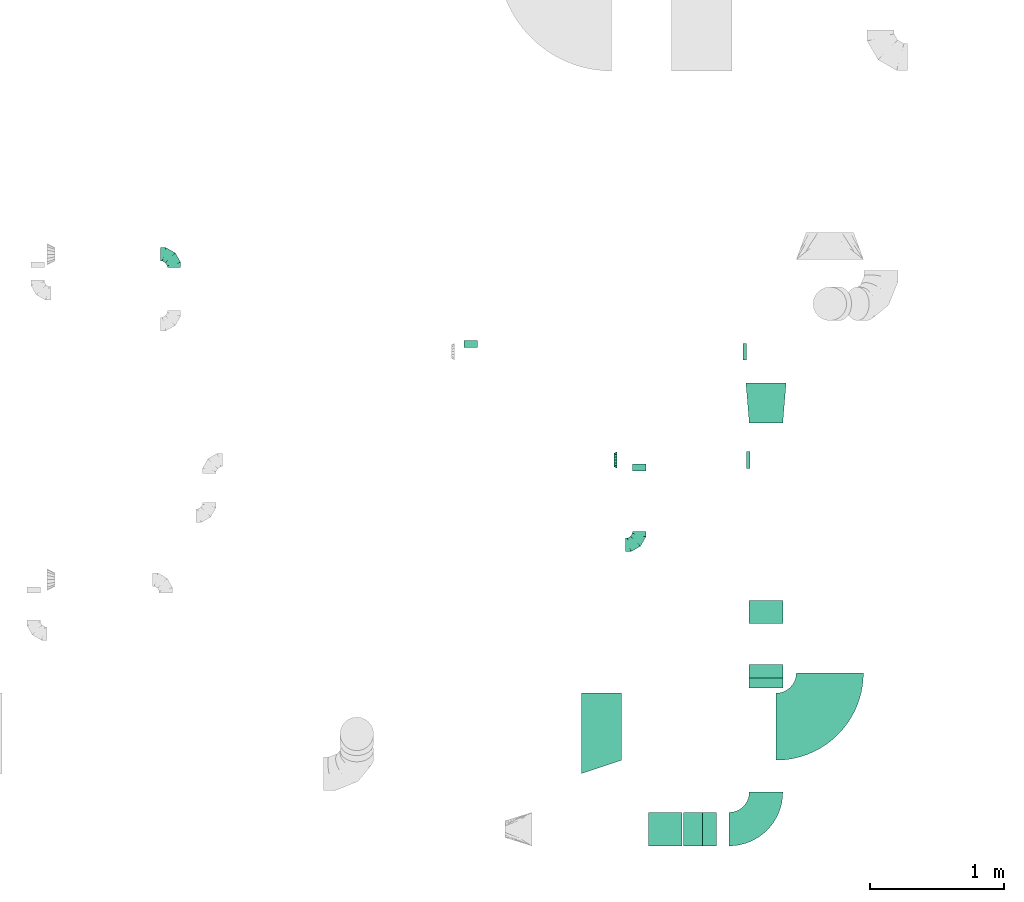
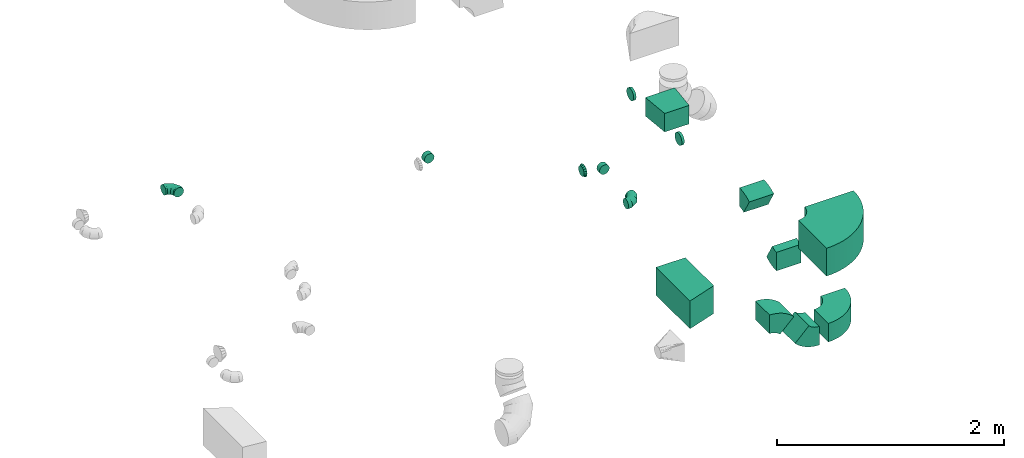
# One storey, part 26 of 62: 15 flow fittings.
"""IFC2X3 building model written with IfcOpenShell, lengths in millimetres."""

from ifc_helpers import new_model, entity, si_unit, converted_unit, derived_unit, direction, frame, frame_2d, origin, place, context, subcontext, project, spatial, polyline, circle_curve, parameter, trimmed, segment, composite_curve, outline, extrude, faceted_brep, source, transform, mapped, material, type_object, type_shapes, element, save


model = new_model("IFC2X3")

# Units and contexts
model_context = context("Model", 3, precision=0.01, world=origin(), true_north=direction((6.12303176911189e-17, 1.0)))
body_context = subcontext(model_context, "Body", "Model", "MODEL_VIEW")
ifc_project = project(units=[si_unit("LENGTHUNIT", "METRE", prefix="MILLI"), si_unit("AREAUNIT", "SQUARE_METRE"), si_unit("VOLUMEUNIT", "CUBIC_METRE"), converted_unit("PLANEANGLEUNIT", "DEGREE", entity("IfcRatioMeasure", 0.0174532925199433), si_unit("PLANEANGLEUNIT", "RADIAN"), dimensions=[0, 0, 0, 0, 0, 0, 0]), si_unit("MASSUNIT", "GRAM", prefix="KILO"), derived_unit("MASSDENSITYUNIT", [(si_unit("MASSUNIT", "GRAM", prefix="KILO"), 1), (si_unit("LENGTHUNIT", "METRE"), -3)]), derived_unit("MOMENTOFINERTIAUNIT", [(si_unit("LENGTHUNIT", "METRE"), 4)]), si_unit("TIMEUNIT", "SECOND"), si_unit("FREQUENCYUNIT", "HERTZ"), si_unit("THERMODYNAMICTEMPERATUREUNIT", "DEGREE_CELSIUS"), derived_unit("THERMALTRANSMITTANCEUNIT", [(si_unit("MASSUNIT", "GRAM", prefix="KILO"), 1), (si_unit("THERMODYNAMICTEMPERATUREUNIT", "KELVIN"), -1), (si_unit("TIMEUNIT", "SECOND"), -3)]), derived_unit("VOLUMETRICFLOWRATEUNIT", [(si_unit("LENGTHUNIT", "METRE"), 3), (si_unit("TIMEUNIT", "SECOND"), -1)]), derived_unit("MASSFLOWRATEUNIT", [(si_unit("MASSUNIT", "GRAM", prefix="KILO"), 1), (si_unit("TIMEUNIT", "SECOND"), -1)]), derived_unit("ROTATIONALFREQUENCYUNIT", [(si_unit("TIMEUNIT", "SECOND"), -1)]), si_unit("ELECTRICCURRENTUNIT", "AMPERE"), si_unit("ELECTRICVOLTAGEUNIT", "VOLT"), si_unit("POWERUNIT", "WATT"), si_unit("FORCEUNIT", "NEWTON", prefix="KILO"), si_unit("ILLUMINANCEUNIT", "LUX"), si_unit("LUMINOUSFLUXUNIT", "LUMEN"), si_unit("LUMINOUSINTENSITYUNIT", "CANDELA"), derived_unit("USERDEFINED", [(si_unit("MASSUNIT", "GRAM", prefix="KILO"), -1), (si_unit("LENGTHUNIT", "METRE"), -2), (si_unit("TIMEUNIT", "SECOND"), 3), (si_unit("LUMINOUSFLUXUNIT", "LUMEN"), 1)]), derived_unit("LINEARVELOCITYUNIT", [(si_unit("LENGTHUNIT", "METRE"), 1), (si_unit("TIMEUNIT", "SECOND"), -1)]), si_unit("PRESSUREUNIT", "PASCAL"), derived_unit("USERDEFINED", [(si_unit("LENGTHUNIT", "METRE"), -2), (si_unit("MASSUNIT", "GRAM", prefix="KILO"), 1), (si_unit("TIMEUNIT", "SECOND"), -2)]), derived_unit("LINEARFORCEUNIT", [(si_unit("MASSUNIT", "GRAM", prefix="KILO"), 1), (si_unit("LENGTHUNIT", "METRE"), 1), (si_unit("TIMEUNIT", "SECOND"), -2), (si_unit("LENGTHUNIT", "METRE"), -1)]), derived_unit("PLANARFORCEUNIT", [(si_unit("MASSUNIT", "GRAM", prefix="KILO"), 1), (si_unit("LENGTHUNIT", "METRE"), 1), (si_unit("TIMEUNIT", "SECOND"), -2), (si_unit("LENGTHUNIT", "METRE"), -2)])], contexts=[model_context])

# Site, building, storey
site_placement = place(None, origin())
site = spatial("IfcSite", under=ifc_project, at=site_placement, CompositionType="ELEMENT")
building_placement = place(site_placement, origin())
building = spatial("IfcBuilding", under=site, at=building_placement, CompositionType="ELEMENT")
storey_placement = place(building_placement, frame((0.0, 0.0, 24000.0)))
storey = spatial("IfcBuildingStorey", under=building, at=storey_placement, CompositionType="ELEMENT", Elevation=24000.0)

# Flow fittings
ifc_material = material()
duct_fitting_type_1 = type_object("IfcDuctFittingType", PredefinedType="NOTDEFINED", material=ifc_material)
shared_shape_1 = source(origin(), body_context, "Body", "SweptSolid", [
    extrude(outline(polyline([(-139.1, -137.03), (161.94, -137.03), (137.03, 161.94), (-159.86, 112.11), (-139.1, -137.03)])), frame((150.0, 0.0, -100.0), z_axis=(0.0, 0.0, 1.0), x_axis=(0.996545758244879, -0.0830454798537418, 0.0)), (0.0, 0.0, 1.0), 200.0),
])
type_shapes(duct_fitting_type_1, [shared_shape_1])
flow_fitting_1_placement = place(storey_placement, frame((40045.11, 3655.67, 3550.0), z_axis=(0.0, 0.0, 1.0), x_axis=(0.0, 1.0, 0.0)))
element("IfcFlowFitting", 1, at=flow_fitting_1_placement, inside=storey, type_object=duct_fitting_type_1, material=ifc_material, context=body_context, shape_type="MappedRepresentation", body=[
    mapped(shared_shape_1, transform((0.0, 0.0, 0.0), scale=1.0)),
])
duct_fitting_type_2 = type_object("IfcDuctFittingType", PredefinedType="NOTDEFINED", material=ifc_material)
shared_shape_2 = source(origin(), body_context, "Body", "SweptSolid", [
    extrude(outline(polyline([(-150.0, -275.0), (150.0, -275.0), (150.0, 325.0), (-150.0, 225.0), (-150.0, -275.0)])), frame((150.0, 25.0, -150.0)), (0.0, 0.0, 1.0), 300.0),
])
type_shapes(duct_fitting_type_2, [shared_shape_2])
flow_fitting_2_placement = place(storey_placement, frame((38970.0, 1394.06, 3500.0), z_axis=(0.0, 0.0, 1.0), x_axis=(-1.0, 0.0, 0.0)))
element("IfcFlowFitting", 2, at=flow_fitting_2_placement, inside=storey, type_object=duct_fitting_type_2, material=ifc_material, context=body_context, shape_type="MappedRepresentation", body=[
    mapped(shared_shape_2, transform((0.0, 0.0, 0.0), scale=1.0)),
])
duct_fitting_type_3 = type_object("IfcDuctFittingType", PredefinedType="NOTDEFINED", material=ifc_material)
shared_shape_3 = source(origin(), body_context, "Body", "Brep", [
    faceted_brep([(-100.0, 0.0, -50.0), (-100.0, -12.94, -48.3), (-100.0, -25.0, -43.3), (-100.0, -35.36, -35.36), (-100.0, -43.3, -25.0), (-100.0, -48.3, -12.94), (-100.0, -50.0, 0.0), (-100.0, -48.3, 12.94), (-100.0, -43.3, 25.0), (-100.0, -35.36, 35.36), (-100.0, -25.0, 43.3), (-100.0, -12.94, 48.3), (-100.0, 0.0, 50.0), (-100.0, 12.94, 48.3), (-100.0, 25.0, 43.3), (-100.0, 35.36, 35.36), (-100.0, 43.3, 25.0), (-100.0, 48.3, 12.94), (-100.0, 50.0, 0.0), (-100.0, 48.3, -12.94), (-100.0, 43.3, -25.0), (-100.0, 35.36, -35.36), (-100.0, 25.0, -43.3), (-100.0, 12.94, -48.3), (-76.67, 12.94, 48.3), (-79.9, 25.0, 43.3), (-73.21, 0.0, 50.0), (-82.68, 35.36, 35.36), (-86.15, 48.3, 12.94), (-86.6, 50.0, 0.0), (-84.81, 43.3, 25.0), (-84.81, 43.3, -25.0), (-82.68, 35.36, -35.36), (-86.15, 48.3, -12.94), (-76.67, 12.94, -48.3), (-73.21, 0.0, -50.0), (-79.9, 25.0, -43.3), (-69.74, -12.94, -48.3), (-66.51, -25.0, -43.3), (-63.73, -35.36, -35.36), (-61.6, -43.3, -25.0), (-60.26, -48.3, -12.94), (-59.81, -50.0, 0.0), (-60.26, -48.3, 12.94), (-61.6, -43.3, 25.0), (-63.73, -35.36, 35.36), (-66.51, -25.0, 43.3), (-69.74, -12.94, 48.3), (-36.27, 36.27, 48.3), (-45.1, 45.1, 43.3), (-26.79, 26.79, 50.0), (-52.68, 52.68, 35.36), (-58.49, 58.49, 25.0), (-62.15, 62.15, 12.94), (-63.4, 63.4, 0.0), (-62.15, 62.15, -12.94), (-58.49, 58.49, -25.0), (-52.68, 52.68, -35.36), (-36.27, 36.27, -48.3), (-26.79, 26.79, -50.0), (-45.1, 45.1, -43.3), (-17.32, 17.32, -48.3), (-8.49, 8.49, -43.3), (-0.91, 0.91, -35.36), (4.9, -4.9, -25.0), (8.56, -8.56, -12.94), (9.81, -9.81, 0.0), (8.56, -8.56, 12.94), (4.9, -4.9, 25.0), (-0.91, 0.91, 35.36), (-8.49, 8.49, 43.3), (-17.32, 17.32, 48.3), (-12.94, 76.67, 48.3), (-25.0, 79.9, 43.3), (0.0, 73.21, 50.0), (-35.36, 82.68, 35.36), (-43.3, 84.81, 25.0), (-48.3, 86.15, 12.94), (-50.0, 86.6, 0.0), (-48.3, 86.15, -12.94), (-43.3, 84.81, -25.0), (-35.36, 82.68, -35.36), (-12.94, 76.67, -48.3), (0.0, 73.21, -50.0), (-25.0, 79.9, -43.3), (12.94, 69.74, -48.3), (25.0, 66.51, -43.3), (35.36, 63.73, -35.36), (43.3, 61.6, -25.0), (48.3, 60.26, -12.94), (50.0, 59.81, 0.0), (48.3, 60.26, 12.94), (43.3, 61.6, 25.0), (35.36, 63.73, 35.36), (25.0, 66.51, 43.3), (12.94, 69.74, 48.3), (-12.94, 100.0, -48.3), (-25.0, 100.0, -43.3), (-35.36, 100.0, -35.36), (-43.3, 100.0, -25.0), (-48.3, 100.0, -12.94), (-50.0, 100.0, 0.0), (-48.3, 100.0, 12.94), (-43.3, 100.0, 25.0), (-35.36, 100.0, 35.36), (-25.0, 100.0, 43.3), (-12.94, 100.0, 48.3), (0.0, 100.0, 50.0), (12.94, 100.0, 48.3), (25.0, 100.0, 43.3), (35.36, 100.0, 35.36), (43.3, 100.0, 25.0), (48.3, 100.0, 12.94), (50.0, 100.0, 0.0), (48.3, 100.0, -12.94), (43.3, 100.0, -25.0), (35.36, 100.0, -35.36), (25.0, 100.0, -43.3), (12.94, 100.0, -48.3), (0.0, 100.0, -50.0)], [[[0, 1, 2, 3, 4, 5, 6, 7, 8, 9, 10, 11, 12, 13, 14, 15, 16, 17, 18, 19, 20, 21, 22, 23]], [[24, 25, 14, 13]], [[26, 24, 13, 12]], [[14, 25, 27, 15]], [[28, 29, 18, 17]], [[30, 28, 17, 16]], [[15, 27, 30, 16]], [[20, 31, 32, 21]], [[33, 31, 20, 19]], [[18, 29, 33, 19]], [[34, 35, 0, 23]], [[36, 34, 23, 22]], [[32, 36, 22, 21]], [[2, 1, 37, 38]], [[3, 2, 38, 39]], [[0, 35, 37, 1]], [[5, 4, 40, 41]], [[6, 5, 41, 42]], [[3, 39, 40, 4]], [[6, 42, 43, 7]], [[7, 43, 44, 8]], [[8, 44, 45, 9]], [[10, 46, 47, 11]], [[11, 47, 26, 12]], [[10, 9, 45, 46]], [[48, 49, 25, 24]], [[50, 48, 24, 26]], [[27, 25, 49, 51]], [[52, 53, 28, 30]], [[51, 52, 30, 27]], [[29, 28, 53, 54]], [[55, 56, 31, 33]], [[54, 55, 33, 29]], [[57, 32, 31, 56]], [[58, 59, 35, 34]], [[60, 58, 34, 36]], [[57, 60, 36, 32]], [[37, 35, 59, 61]], [[38, 37, 61, 62]], [[39, 38, 62, 63]], [[41, 40, 64, 65]], [[42, 41, 65, 66]], [[63, 64, 40, 39]], [[43, 42, 66, 67]], [[44, 43, 67, 68]], [[68, 69, 45, 44]], [[46, 45, 69, 70]], [[47, 46, 70, 71]], [[26, 47, 71, 50]], [[72, 73, 49, 48]], [[74, 72, 48, 50]], [[51, 49, 73, 75]], [[76, 77, 53, 52]], [[75, 76, 52, 51]], [[54, 53, 77, 78]], [[79, 80, 56, 55]], [[78, 79, 55, 54]], [[81, 57, 56, 80]], [[82, 83, 59, 58]], [[84, 82, 58, 60]], [[81, 84, 60, 57]], [[61, 59, 83, 85]], [[62, 61, 85, 86]], [[63, 62, 86, 87]], [[65, 64, 88, 89]], [[66, 65, 89, 90]], [[87, 88, 64, 63]], [[67, 66, 90, 91]], [[68, 67, 91, 92]], [[92, 93, 69, 68]], [[70, 69, 93, 94]], [[71, 70, 94, 95]], [[50, 71, 95, 74]], [[96, 97, 98, 99, 100, 101, 102, 103, 104, 105, 106, 107, 108, 109, 110, 111, 112, 113, 114, 115, 116, 117, 118, 119]], [[72, 74, 107, 106]], [[73, 72, 106, 105]], [[75, 73, 105, 104]], [[77, 76, 103, 102]], [[78, 77, 102, 101]], [[75, 104, 103, 76]], [[78, 101, 100, 79]], [[79, 100, 99, 80]], [[80, 99, 98, 81]], [[96, 119, 83, 82]], [[97, 96, 82, 84]], [[84, 81, 98, 97]], [[83, 119, 118, 85]], [[85, 118, 117, 86]], [[86, 117, 116, 87]], [[88, 115, 114, 89]], [[89, 114, 113, 90]], [[87, 116, 115, 88]], [[91, 90, 113, 112]], [[92, 91, 112, 111]], [[93, 92, 111, 110]], [[95, 94, 109, 108]], [[74, 95, 108, 107]], [[110, 109, 94, 93]]]),
])
type_shapes(duct_fitting_type_3, [shared_shape_3])
flow_fitting_3_placement = place(storey_placement, frame((39099.75, 2747.74, 3550.0)))
element("IfcFlowFitting", 3, at=flow_fitting_3_placement, inside=storey, type_object=duct_fitting_type_3, material=ifc_material, context=body_context, shape_type="MappedRepresentation", body=[
    mapped(shared_shape_3, transform((0.0, 0.0, 0.0), scale=1.0)),
])
flow_fitting_4_placement = place(storey_placement, frame((35635.5, 4912.39, 3600.0), z_axis=(0.0, 0.0, 1.0), x_axis=(0.0, 1.0, 0.0)))
element("IfcFlowFitting", 4, at=flow_fitting_4_placement, inside=storey, type_object=duct_fitting_type_3, material=ifc_material, context=body_context, shape_type="MappedRepresentation", body=[
    mapped(shared_shape_3, transform((0.0, 0.0, 0.0), scale=1.0)),
])
duct_fitting_type_4 = type_object("IfcDuctFittingType", PredefinedType="NOTDEFINED", material=ifc_material)
shared_shape_4 = source(origin(), body_context, "Body", "Brep", [
    faceted_brep([(20.0, 16.18, -60.37), (20.0, 31.25, -54.13), (20.0, 44.19, -44.19), (20.0, 54.13, -31.25), (20.0, 60.37, -16.18), (20.0, 62.5, 0.0), (20.0, 60.37, 16.18), (20.0, 54.13, 31.25), (20.0, 44.19, 44.19), (20.0, 31.25, 54.13), (20.0, 16.18, 60.37), (20.0, 0.0, 62.5), (20.0, -16.18, 60.37), (20.0, -31.25, 54.13), (20.0, -44.19, 44.19), (20.0, -54.13, 31.25), (20.0, -60.37, 16.18), (20.0, -62.5, 0.0), (20.0, -60.37, -16.18), (20.0, -54.13, -31.25), (20.0, -44.19, -44.19), (20.0, -31.25, -54.13), (20.0, -16.18, -60.37), (20.0, 0.0, -62.5), (0.0, 0.0, 62.5), (0.0, 16.18, 60.37), (-6.1, 16.18, 60.37), (-6.1, 0.0, 62.5), (0.0, 31.25, 54.13), (-6.1, 31.25, 54.13), (0.0, 44.19, 44.19), (-6.1, 44.19, 44.19), (0.0, 54.13, 31.25), (0.0, 60.37, 16.18), (-6.1, 60.37, 16.18), (-6.1, 54.13, 31.25), (0.0, 62.5, 0.0), (-6.1, 62.5, 0.0), (0.0, 60.37, -16.18), (-6.1, 60.37, -16.18), (0.0, 54.13, -31.25), (-6.1, 54.13, -31.25), (0.0, 44.19, -44.19), (-6.1, 44.19, -44.19), (0.0, 31.25, -54.13), (0.0, 16.18, -60.37), (-6.1, 16.18, -60.37), (-6.1, 31.25, -54.13), (0.0, 0.0, -62.5), (-6.1, 0.0, -62.5), (0.0, -16.18, -60.37), (-6.1, -16.18, -60.37), (0.0, -31.25, -54.13), (-6.1, -31.25, -54.13), (0.0, -44.19, -44.19), (-6.1, -44.19, -44.19), (0.0, -54.13, -31.25), (0.0, -60.37, -16.18), (-6.1, -60.37, -16.18), (-6.1, -54.13, -31.25), (0.0, -62.5, 0.0), (-6.1, -62.5, 0.0), (0.0, -60.37, 16.18), (-6.1, -60.37, 16.18), (0.0, -54.13, 31.25), (-6.1, -54.13, 31.25), (0.0, -44.19, 44.19), (-6.1, -44.19, 44.19), (0.0, -31.25, 54.13), (0.0, -16.18, 60.37), (-6.1, -16.18, 60.37), (-6.1, -31.25, 54.13)], [[[0, 1, 2, 3, 4, 5, 6, 7, 8, 9, 10, 11, 12, 13, 14, 15, 16, 17, 18, 19, 20, 21, 22, 23]], [[24, 11, 10, 25, 26, 27]], [[25, 10, 9, 28, 29, 26]], [[28, 9, 8, 30, 31, 29]], [[32, 7, 6, 33, 34, 35]], [[33, 6, 5, 36, 37, 34]], [[30, 8, 7, 32, 35, 31]], [[36, 5, 4, 38, 39, 37]], [[38, 4, 3, 40, 41, 39]], [[40, 3, 2, 42, 43, 41]], [[44, 1, 0, 45, 46, 47]], [[45, 0, 23, 48, 49, 46]], [[42, 2, 1, 44, 47, 43]], [[48, 23, 22, 50, 51, 49]], [[50, 22, 21, 52, 53, 51]], [[52, 21, 20, 54, 55, 53]], [[56, 19, 18, 57, 58, 59]], [[57, 18, 17, 60, 61, 58]], [[54, 20, 19, 56, 59, 55]], [[60, 17, 16, 62, 63, 61]], [[62, 16, 15, 64, 65, 63]], [[64, 15, 14, 66, 67, 65]], [[68, 13, 12, 69, 70, 71]], [[69, 12, 11, 24, 27, 70]], [[66, 14, 13, 68, 71, 67]], [[49, 51, 53, 55, 59, 58, 61, 63, 65, 67, 71, 70, 27, 26, 29, 31, 35, 34, 37, 39, 41, 43, 47, 46]]]),
])
type_shapes(duct_fitting_type_4, [shared_shape_4])
for number, where, z_axis, x_axis in (
    (5, (39895.11, 4187.21, 3550.0), (0.0, 0.0, -1.0), (-1.0, 0.0, 0.0)),
    (6, (39920.11, 3380.24, 3550.0), (0.0, 0.0, -1.0), (-1.0, 0.0, 0.0)),
):
    element("IfcFlowFitting", number, at=place(storey_placement, frame(where, z_axis=z_axis, x_axis=x_axis)), inside=storey, type_object=duct_fitting_type_4, material=ifc_material, context=body_context, shape_type="MappedRepresentation", body=[
        mapped(shared_shape_4, transform((0.0, 0.0, 0.0), scale=1.0)),
    ])
duct_fitting_type_5 = type_object("IfcDuctFittingType", PredefinedType="NOTDEFINED", material=ifc_material)
shared_shape_5 = source(origin(), body_context, "Body", "Brep", [
    faceted_brep([(25.0, -46.19, 19.13), (25.0, -48.1, 9.57), (25.0, -50.0, 0.0), (25.0, -48.1, -9.57), (25.0, -46.19, -19.13), (25.0, -40.77, -27.24), (25.0, -35.36, -35.36), (25.0, -27.24, -40.77), (25.0, -19.13, -46.19), (25.0, -9.57, -48.1), (25.0, 0.0, -50.0), (25.0, 9.57, -48.1), (25.0, 19.13, -46.19), (25.0, 27.24, -40.77), (25.0, 35.36, -35.36), (25.0, 40.77, -27.24), (25.0, 46.19, -19.13), (25.0, 48.1, -9.57), (25.0, 50.0, 0.0), (25.0, 48.1, 9.57), (25.0, 46.19, 19.13), (25.0, 40.77, 27.24), (25.0, 35.36, 35.36), (25.0, 27.24, 40.77), (25.0, 19.13, 46.19), (25.0, 9.57, 48.1), (25.0, 0.0, 50.0), (25.0, -9.57, 48.1), (25.0, -19.13, 46.19), (25.0, -27.24, 40.77), (25.0, -35.36, 35.36), (25.0, -40.77, 27.24), (0.0, -62.5, 0.0), (0.0, -60.02, 12.45), (0.0, -57.74, 23.92), (0.0, -50.97, 34.06), (0.0, -44.19, 44.19), (0.0, -34.06, 50.97), (0.0, -23.92, 57.74), (0.0, -12.45, 60.02), (0.0, 0.0, 62.5), (0.0, 12.45, 60.02), (0.0, 23.92, 57.74), (0.0, 34.06, 50.97), (0.0, 44.19, 44.19), (0.0, 50.97, 34.06), (0.0, 57.74, 23.92), (0.0, 60.02, 12.45), (0.0, 62.5, 0.0), (0.0, 60.02, -12.45), (0.0, 57.74, -23.92), (0.0, 50.97, -34.06), (0.0, 44.19, -44.19), (0.0, 34.06, -50.97), (0.0, 23.92, -57.74), (0.0, 12.45, -60.02), (0.0, 0.0, -62.5), (0.0, -12.45, -60.02), (0.0, -23.92, -57.74), (0.0, -34.06, -50.97), (0.0, -44.19, -44.19), (0.0, -50.97, -34.06), (0.0, -57.74, -23.92), (0.0, -60.02, -12.45)], [[[0, 1, 2, 3, 4, 5, 6, 7, 8, 9, 10, 11, 12, 13, 14, 15, 16, 17, 18, 19, 20, 21, 22, 23, 24, 25, 26, 27, 28, 29, 30, 31]], [[32, 33, 34, 35, 36, 37, 38, 39, 40, 41, 42, 43, 44, 45, 46, 47, 48, 49, 50, 51, 52, 53, 54, 55, 56, 57, 58, 59, 60, 61, 62, 63]], [[24, 42, 41, 40, 26, 25]], [[22, 44, 43, 42, 24, 23]], [[48, 47, 46, 20, 19, 18]], [[44, 22, 21, 20, 46, 45]], [[0, 34, 33, 32, 2, 1]], [[30, 36, 35, 34, 0, 31]], [[40, 39, 38, 28, 27, 26]], [[36, 30, 29, 28, 38, 37]], [[8, 58, 57, 56, 10, 9]], [[6, 60, 59, 58, 8, 7]], [[32, 63, 62, 4, 3, 2]], [[60, 6, 5, 4, 62, 61]], [[16, 50, 49, 48, 18, 17]], [[14, 52, 51, 50, 16, 15]], [[56, 55, 54, 12, 11, 10]], [[52, 14, 13, 12, 54, 53]]]),
])
type_shapes(duct_fitting_type_5, [shared_shape_5])
flow_fitting_5_placement = place(storey_placement, frame((38935.98, 3380.24, 3550.0), z_axis=(0.0, 0.0, 1.0), x_axis=(-1.0, 0.0, 0.0)))
element("IfcFlowFitting", 7, at=flow_fitting_5_placement, inside=storey, type_object=duct_fitting_type_5, material=ifc_material, context=body_context, shape_type="MappedRepresentation", body=[
    mapped(shared_shape_5, transform((0.0, 0.0, 0.0), scale=1.0)),
])
duct_fitting_type_6 = type_object("IfcDuctFittingType", PredefinedType="NOTDEFINED", material=ifc_material)
shared_shape_6 = source(origin(), body_context, "Body", "Brep", [
    faceted_brep([(20.0, 12.94, -48.3), (20.0, 25.0, -43.3), (20.0, 35.36, -35.36), (20.0, 43.3, -25.0), (20.0, 48.3, -12.94), (20.0, 50.0, 0.0), (20.0, 48.3, 12.94), (20.0, 43.3, 25.0), (20.0, 35.36, 35.36), (20.0, 25.0, 43.3), (20.0, 12.94, 48.3), (20.0, 0.0, 50.0), (20.0, -12.94, 48.3), (20.0, -25.0, 43.3), (20.0, -35.36, 35.36), (20.0, -43.3, 25.0), (20.0, -48.3, 12.94), (20.0, -50.0, 0.0), (20.0, -48.3, -12.94), (20.0, -43.3, -25.0), (20.0, -35.36, -35.36), (20.0, -25.0, -43.3), (20.0, -12.94, -48.3), (20.0, 0.0, -50.0), (0.0, 0.0, 50.0), (0.0, 12.94, 48.3), (-31.1, 12.94, 48.3), (-31.1, 0.0, 50.0), (0.0, 25.0, 43.3), (-31.1, 25.0, 43.3), (0.0, 35.36, 35.36), (-31.1, 35.36, 35.36), (0.0, 43.3, 25.0), (0.0, 48.3, 12.94), (-31.1, 48.3, 12.94), (-31.1, 43.3, 25.0), (0.0, 50.0, 0.0), (-31.1, 50.0, 0.0), (0.0, 48.3, -12.94), (-31.1, 48.3, -12.94), (0.0, 43.3, -25.0), (-31.1, 43.3, -25.0), (0.0, 35.36, -35.36), (-31.1, 35.36, -35.36), (0.0, 25.0, -43.3), (0.0, 12.94, -48.3), (-31.1, 12.94, -48.3), (-31.1, 25.0, -43.3), (0.0, 0.0, -50.0), (-31.1, 0.0, -50.0), (0.0, -12.94, -48.3), (-31.1, -12.94, -48.3), (0.0, -25.0, -43.3), (-31.1, -25.0, -43.3), (0.0, -35.36, -35.36), (-31.1, -35.36, -35.36), (0.0, -43.3, -25.0), (0.0, -48.3, -12.94), (-31.1, -48.3, -12.94), (-31.1, -43.3, -25.0), (0.0, -50.0, 0.0), (-31.1, -50.0, 0.0), (0.0, -48.3, 12.94), (-31.1, -48.3, 12.94), (0.0, -43.3, 25.0), (-31.1, -43.3, 25.0), (0.0, -35.36, 35.36), (-31.1, -35.36, 35.36), (0.0, -25.0, 43.3), (0.0, -12.94, 48.3), (-31.1, -12.94, 48.3), (-31.1, -25.0, 43.3)], [[[0, 1, 2, 3, 4, 5, 6, 7, 8, 9, 10, 11, 12, 13, 14, 15, 16, 17, 18, 19, 20, 21, 22, 23]], [[24, 11, 10, 25, 26, 27]], [[25, 10, 9, 28, 29, 26]], [[28, 9, 8, 30, 31, 29]], [[32, 7, 6, 33, 34, 35]], [[33, 6, 5, 36, 37, 34]], [[30, 8, 7, 32, 35, 31]], [[36, 5, 4, 38, 39, 37]], [[38, 4, 3, 40, 41, 39]], [[40, 3, 2, 42, 43, 41]], [[44, 1, 0, 45, 46, 47]], [[45, 0, 23, 48, 49, 46]], [[42, 2, 1, 44, 47, 43]], [[48, 23, 22, 50, 51, 49]], [[50, 22, 21, 52, 53, 51]], [[52, 21, 20, 54, 55, 53]], [[56, 19, 18, 57, 58, 59]], [[57, 18, 17, 60, 61, 58]], [[54, 20, 19, 56, 59, 55]], [[60, 17, 16, 62, 63, 61]], [[62, 16, 15, 64, 65, 63]], [[64, 15, 14, 66, 67, 65]], [[68, 13, 12, 69, 70, 71]], [[69, 12, 11, 24, 27, 70]], [[66, 14, 13, 68, 71, 67]], [[49, 51, 53, 55, 59, 58, 61, 63, 65, 67, 71, 70, 27, 26, 29, 31, 35, 34, 37, 39, 41, 43, 47, 46]]]),
])
type_shapes(duct_fitting_type_6, [shared_shape_6])
flow_fitting_6_placement = place(storey_placement, frame((37846.39, 4249.71, 3550.0), z_axis=(0.0, 0.0, -1.0), x_axis=(0.0, 1.0, 0.0)))
element("IfcFlowFitting", 8, at=flow_fitting_6_placement, inside=storey, type_object=duct_fitting_type_6, material=ifc_material, context=body_context, shape_type="MappedRepresentation", body=[
    mapped(shared_shape_6, transform((0.0, 0.0, 0.0), scale=1.0)),
])
duct_fitting_type_7 = type_object("IfcDuctFittingType", PredefinedType="NOTDEFINED", material=ifc_material)
shared_shape_7 = source(origin(), body_context, "Body", "Brep", [
    faceted_brep([(20.0, 0.0, -50.0), (20.0, 12.94, -48.3), (20.0, 25.0, -43.3), (20.0, 35.36, -35.36), (20.0, 43.3, -25.0), (20.0, 48.3, -12.94), (20.0, 50.0, 0.0), (20.0, 48.3, 12.94), (20.0, 43.3, 25.0), (20.0, 35.36, 35.36), (20.0, 25.0, 43.3), (20.0, 12.94, 48.3), (20.0, 0.0, 50.0), (20.0, -12.94, 48.3), (20.0, -25.0, 43.3), (20.0, -35.36, 35.36), (20.0, -43.3, 25.0), (20.0, -48.3, 12.94), (20.0, -50.0, 0.0), (20.0, -48.3, -12.94), (20.0, -43.3, -25.0), (20.0, -35.36, -35.36), (20.0, -25.0, -43.3), (20.0, -12.94, -48.3), (0.0, 0.0, 50.0), (-31.1, 0.0, 50.0), (-31.1, -12.94, 48.3), (0.0, -12.94, 48.3), (-31.1, -25.0, 43.3), (0.0, -25.0, 43.3), (0.0, -35.36, 35.36), (-31.1, -35.36, 35.36), (0.0, -43.3, 25.0), (-31.1, -43.3, 25.0), (-31.1, -48.3, 12.94), (0.0, -48.3, 12.94), (-31.1, -50.0, 0.0), (0.0, -50.0, 0.0), (-31.1, -48.3, -12.94), (0.0, -48.3, -12.94), (-31.1, -43.3, -25.0), (0.0, -43.3, -25.0), (0.0, -35.36, -35.36), (-31.1, -35.36, -35.36), (0.0, -25.0, -43.3), (-31.1, -25.0, -43.3), (-31.1, -12.94, -48.3), (0.0, -12.94, -48.3), (-31.1, 0.0, -50.0), (0.0, 0.0, -50.0), (-31.1, 12.94, -48.3), (0.0, 12.94, -48.3), (-31.1, 25.0, -43.3), (0.0, 25.0, -43.3), (0.0, 35.36, -35.36), (-31.1, 35.36, -35.36), (0.0, 43.3, -25.0), (-31.1, 43.3, -25.0), (-31.1, 48.3, -12.94), (0.0, 48.3, -12.94), (-31.1, 50.0, 0.0), (0.0, 50.0, 0.0), (-31.1, 48.3, 12.94), (0.0, 48.3, 12.94), (-31.1, 43.3, 25.0), (0.0, 43.3, 25.0), (0.0, 35.36, 35.36), (-31.1, 35.36, 35.36), (0.0, 25.0, 43.3), (-31.1, 25.0, 43.3), (-31.1, 12.94, 48.3), (0.0, 12.94, 48.3)], [[[0, 1, 2, 3, 4, 5, 6, 7, 8, 9, 10, 11, 12, 13, 14, 15, 16, 17, 18, 19, 20, 21, 22, 23]], [[13, 12, 24, 25, 26, 27]], [[14, 13, 27, 26, 28, 29]], [[30, 15, 14, 29, 28, 31]], [[17, 16, 32, 33, 34, 35]], [[18, 17, 35, 34, 36, 37]], [[32, 16, 15, 30, 31, 33]], [[19, 18, 37, 36, 38, 39]], [[20, 19, 39, 38, 40, 41]], [[42, 21, 20, 41, 40, 43]], [[23, 22, 44, 45, 46, 47]], [[0, 23, 47, 46, 48, 49]], [[44, 22, 21, 42, 43, 45]], [[1, 0, 49, 48, 50, 51]], [[2, 1, 51, 50, 52, 53]], [[54, 3, 2, 53, 52, 55]], [[5, 4, 56, 57, 58, 59]], [[6, 5, 59, 58, 60, 61]], [[56, 4, 3, 54, 55, 57]], [[7, 6, 61, 60, 62, 63]], [[8, 7, 63, 62, 64, 65]], [[66, 9, 8, 65, 64, 67]], [[11, 10, 68, 69, 70, 71]], [[12, 11, 71, 70, 25, 24]], [[68, 10, 9, 66, 67, 69]], [[46, 45, 43, 40, 38, 36, 34, 33, 31, 28, 26, 25, 70, 69, 67, 64, 62, 60, 58, 57, 55, 52, 50, 48]]]),
])
type_shapes(duct_fitting_type_7, [shared_shape_7])
flow_fitting_7_placement = place(storey_placement, frame((39099.75, 3317.74, 3550.0), z_axis=(0.0, 0.0, -1.0), x_axis=(0.0, -1.0, 0.0)))
element("IfcFlowFitting", 9, at=flow_fitting_7_placement, inside=storey, type_object=duct_fitting_type_7, material=ifc_material, context=body_context, shape_type="MappedRepresentation", body=[
    mapped(shared_shape_7, transform((0.0, 0.0, 0.0), scale=1.0)),
])
duct_fitting_type_8 = type_object("IfcDuctFittingType", PredefinedType="NOTDEFINED", material=ifc_material)
shared_shape_8 = source(origin(), body_context, "Body", "SweptSolid", [
    extrude(outline(composite_curve([segment(polyline([(-262.5, -137.5), (-12.5, -137.5)]), True, "CONTINUOUS"), segment(trimmed(circle_curve(frame_2d((137.5, -137.5), x_axis=(0.0, 1.0)), 150.0), [parameter(0.0)], [parameter(90.0000000000001)], True, "PARAMETER"), False, "CONTINUOUS"), segment(polyline([(137.5, 12.5), (137.5, 262.5)]), True, "CONTINUOUS"), segment(trimmed(circle_curve(frame_2d((137.5, -137.5), x_axis=(0.0, 1.0)), 400.0), [parameter(0.0)], [parameter(90.0000000000001)], True, "PARAMETER"), True, "CONTINUOUS")], self_intersect=False)), frame((-137.5, 137.5, -100.0), z_axis=(0.0, 0.0, 1.0), x_axis=(-1.0, 0.0, 0.0)), (0.0, 0.0, 1.0), 200.0),
])
type_shapes(duct_fitting_type_8, [shared_shape_8])
flow_fitting_8_placement = place(storey_placement, frame((40045.11, 630.67, 3250.0)))
element("IfcFlowFitting", 10, at=flow_fitting_8_placement, inside=storey, type_object=duct_fitting_type_8, material=ifc_material, context=body_context, shape_type="MappedRepresentation", body=[
    mapped(shared_shape_8, transform((0.0, 0.0, 0.0), scale=1.0)),
])
duct_fitting_type_9 = type_object("IfcDuctFittingType", PredefinedType="NOTDEFINED", material=ifc_material)
shared_shape_9 = source(origin(), body_context, "Body", "SweptSolid", [
    extrude(outline(composite_curve([segment(polyline([(-450.0, -200.0), (50.0, -200.0)]), True, "CONTINUOUS"), segment(trimmed(circle_curve(frame_2d((200.0, -200.0), x_axis=(0.0, 1.0)), 150.0), [parameter(0.0)], [parameter(90.0000000000001)], True, "PARAMETER"), False, "CONTINUOUS"), segment(polyline([(200.0, -50.0), (200.0, 450.0)]), True, "CONTINUOUS"), segment(trimmed(circle_curve(frame_2d((200.0, -200.0), x_axis=(0.0, 1.0)), 650.0), [parameter(0.0)], [parameter(90.0000000000001)], True, "PARAMETER"), True, "CONTINUOUS")], self_intersect=False)), frame((-200.0, 200.0, -150.0), z_axis=(0.0, 0.0, 1.0), x_axis=(-1.0, 0.0, 0.0)), (0.0, 0.0, 1.0), 300.0),
])
type_shapes(duct_fitting_type_9, [shared_shape_9])
flow_fitting_9_placement = place(storey_placement, frame((40520.63, 1394.06, 3500.0)))
element("IfcFlowFitting", 11, at=flow_fitting_9_placement, inside=storey, type_object=duct_fitting_type_9, material=ifc_material, context=body_context, shape_type="MappedRepresentation", body=[
    mapped(shared_shape_9, transform((0.0, 0.0, 0.0), scale=1.0)),
])
duct_fitting_type_10 = type_object("IfcDuctFittingType", PredefinedType="NOTDEFINED", material=ifc_material)
shared_shape_10 = source(origin(), body_context, "Body", "SweptSolid", [
    extrude(outline(composite_curve([segment(polyline([(-116.75, -62.5), (83.25, -62.5)]), True, "CONTINUOUS"), segment(trimmed(circle_curve(frame_2d((233.25, -62.5), x_axis=(-0.86602541071267, 0.499999987999949)), 150.0), [parameter(0.0)], [parameter(29.999999206083)], True, "PARAMETER"), False, "CONTINUOUS"), segment(polyline([(103.35, 12.5), (-69.86, 112.5)]), True, "CONTINUOUS"), segment(trimmed(circle_curve(frame_2d((233.25, -62.5), x_axis=(-0.86602541071267, 0.499999987999949)), 350.0), [parameter(0.0)], [parameter(29.999999206083)], True, "PARAMETER"), True, "CONTINUOUS")], self_intersect=False)), frame((-4.49, 16.75, -125.0), z_axis=(0.0, 0.0, 1.0), x_axis=(-0.499999987999949, 0.866025410712671, 0.0)), (0.0, 0.0, 1.0), 250.0),
])
type_shapes(duct_fitting_type_10, [shared_shape_10])
for number, where, z_axis, x_axis in (
    (12, (40045.11, 2268.67, 3550.0), (1.0, 0.0, 0.0), (0.0, -1.0, 0.0)),
    (13, (40045.11, 1749.06, 3250.0), (-1.0, 0.0, 0.0), (0.0, -0.866025410712631, -0.499999988000018)),
):
    element("IfcFlowFitting", number, at=place(storey_placement, frame(where, z_axis=z_axis, x_axis=x_axis)), inside=storey, type_object=duct_fitting_type_10, material=ifc_material, context=body_context, shape_type="MappedRepresentation", body=[
        mapped(shared_shape_10, transform((0.0, 0.0, 0.0), scale=1.0)),
    ])
duct_fitting_type_11 = type_object("IfcDuctFittingType", PredefinedType="NOTDEFINED", material=ifc_material)
shared_shape_11 = source(origin(), body_context, "Body", "SweptSolid", [
    extrude(outline(composite_curve([segment(polyline([(-136.61, -88.39), (63.39, -88.39)]), True, "CONTINUOUS"), segment(trimmed(circle_curve(frame_2d((213.39, -88.39), x_axis=(-0.707106781186546, 0.707106781186546)), 150.0), [parameter(0.0)], [parameter(45.0)], True, "PARAMETER"), False, "CONTINUOUS"), segment(polyline([(107.32, 17.68), (-34.1, 159.1)]), True, "CONTINUOUS"), segment(trimmed(circle_curve(frame_2d((213.39, -88.39), x_axis=(-0.707106781186546, 0.707106781186546)), 350.0), [parameter(0.0)], [parameter(45.0)], True, "PARAMETER"), True, "CONTINUOUS")], self_intersect=False)), frame((-15.17, 36.61, -125.0), z_axis=(0.0, 0.0, 1.0), x_axis=(-0.707106781186547, 0.707106781186548, 0.0)), (0.0, 0.0, 1.0), 250.0),
])
type_shapes(duct_fitting_type_11, [shared_shape_11])
for number, where, z_axis, x_axis in (
    (14, (39574.39, 630.67, 3250.0), (0.0, 1.0, 0.0), (-1.0, 0.0, 0.0)),
    (15, (39274.39, 630.67, 3550.0), (0.0, -1.0, 0.0), (-0.707106781186534, 0.0, 0.707106781186561)),
):
    element("IfcFlowFitting", number, at=place(storey_placement, frame(where, z_axis=z_axis, x_axis=x_axis)), inside=storey, type_object=duct_fitting_type_11, material=ifc_material, context=body_context, shape_type="MappedRepresentation", body=[
        mapped(shared_shape_11, transform((0.0, 0.0, 0.0), scale=1.0)),
    ])

save(model, "model.ifc")
